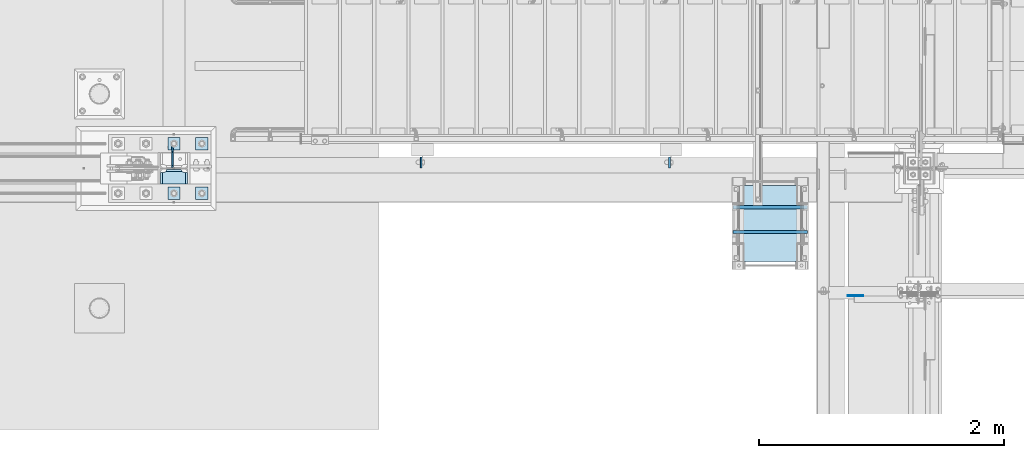
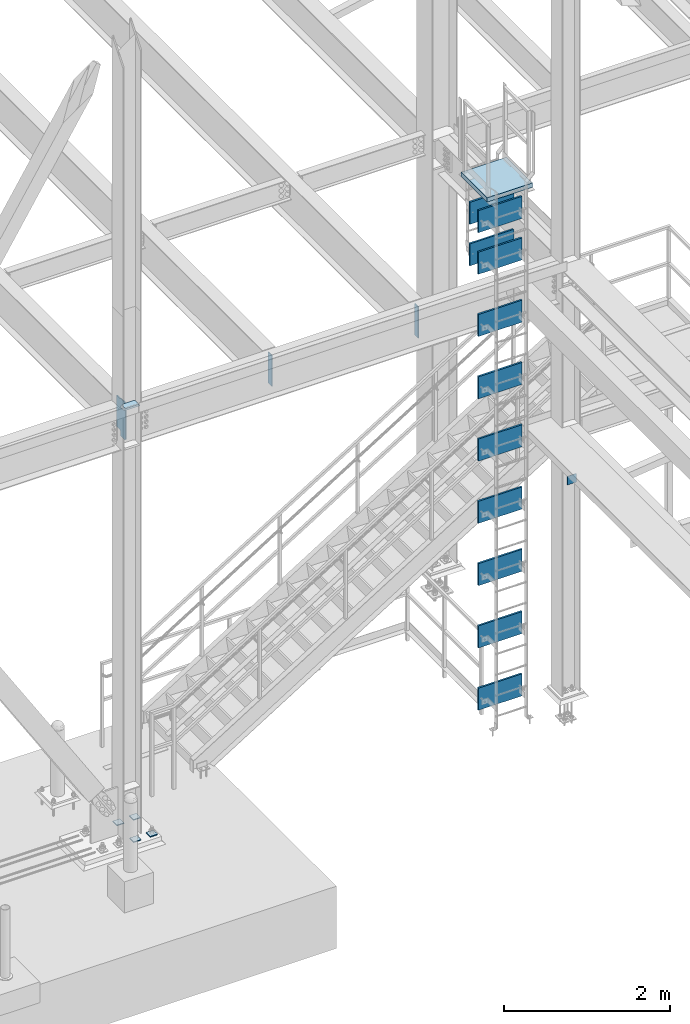
# One storey, part 3404 of 3843: 21 plates, 16 elements without a shape of their own.
"""IFC2X3 building model written with IfcOpenShell, lengths in millimetres."""

from ifc_helpers import new_model, si_unit, frame, origin_with_axes, place, context, subcontext, project, spatial, faceted_brep, material, type_object, element, aggregate, save


model = new_model("IFC2X3")

# Units and contexts
model_context = context("Model", 3, precision=1e-05, world=origin_with_axes())
body_context = subcontext(model_context, "Body", "Model", "MODEL_VIEW")
ifc_project = project(units=[si_unit("LENGTHUNIT", "METRE", prefix="MILLI"), si_unit("AREAUNIT", "SQUARE_METRE"), si_unit("VOLUMEUNIT", "CUBIC_METRE"), si_unit("MASSUNIT", "GRAM", prefix="KILO"), si_unit("TIMEUNIT", "SECOND"), si_unit("PLANEANGLEUNIT", "RADIAN"), si_unit("SOLIDANGLEUNIT", "STERADIAN"), si_unit("THERMODYNAMICTEMPERATUREUNIT", "DEGREE_CELSIUS"), si_unit("LUMINOUSINTENSITYUNIT", "LUMEN")], contexts=[model_context])

# Site, building, storey
site_placement = place(None, origin_with_axes())
site = spatial("IfcSite", under=ifc_project, at=site_placement, CompositionType="ELEMENT")
building_placement = place(site_placement, origin_with_axes())
building = spatial("IfcBuilding", under=site, at=building_placement, Name="Undefined", CompositionType="ELEMENT")
storey_placement = place(building_placement, origin_with_axes())
storey = spatial("IfcBuildingStorey", under=building, at=storey_placement, Name="Undefined", CompositionType="ELEMENT", Elevation=0.0)

# Assembly, plate
assembly_1_placement = place(storey_placement, origin_with_axes())
assembly_1 = element("IfcElementAssembly", 1, at=assembly_1_placement, inside=storey, Name="PLYWOOD", AssemblyPlace="NOTDEFINED", PredefinedType="NOTDEFINED")
ifc_material_1 = material(Name="TIMBER/PLYWOOD")
plate_type_1 = type_object("IfcPlateType", PredefinedType="NOTDEFINED")
plate_1_placement = place(assembly_1_placement, frame((35356.7999999986, 88811.8271118164, 37345.1994628906), z_axis=(0.0, 0.0, -1.0), x_axis=(0.0, -1.0, 0.0)))
plate_1 = element("IfcPlate", 2, at=plate_1_placement, type_object=plate_type_1, material=ifc_material_1, Name="PLYWOOD", context=body_context, shape_type="Brep", body=[
    faceted_brep([(0.0, -304.799999999999, 0.0), (0.0, -304.800000000003, 323.849999999999), (0.0, 304.800000000003, 323.849999999999), (0.0, 304.799999999999, 0.0), (25.3999999999942, -304.800000000003, 323.849999999999), (25.3999999999942, 304.800000000003, 323.849999999999), (25.4000000002561, -304.799999999999, -8.00355337560177e-11), (25.4000000002561, 304.799999999999, -8.00355337560177e-11)], [[[0, 1, 2, 3]], [[1, 4, 5, 2]], [[4, 6, 7, 5]], [[6, 0, 3, 7]], [[5, 7, 3, 2]], [[6, 4, 1, 0]]]),
])
aggregate(assembly_1, [plate_1])

assembly_2_placement = place(storey_placement, origin_with_axes())
assembly_2 = element("IfcElementAssembly", 3, at=assembly_2_placement, inside=storey, Name="PLYWOOD", AssemblyPlace="NOTDEFINED", PredefinedType="NOTDEFINED")
plate_2_placement = place(assembly_2_placement, frame((35356.7999023562, 88608.6271118164, 30944.3968505849), z_axis=(0.0, 0.0, -1.0), x_axis=(0.0, -1.0, 0.0)))
plate_2 = element("IfcPlate", 4, at=plate_2_placement, type_object=plate_type_1, material=ifc_material_1, Name="PLYWOOD", context=body_context, shape_type="Brep", body=[
    faceted_brep([(0.0, -304.799999999999, 0.0), (0.0, -304.800000000003, 323.849999999999), (0.0, 304.800000000003, 323.849999999999), (0.0, 304.799999999999, 0.0), (25.3999999999942, -304.800000000003, 323.849999999999), (25.3999999999942, 304.800000000003, 323.849999999999), (25.4000000002561, -304.799999999999, -8.00355337560177e-11), (25.4000000002561, 304.799999999999, -8.00355337560177e-11)], [[[0, 1, 2, 3]], [[1, 4, 5, 2]], [[4, 6, 7, 5]], [[6, 0, 3, 7]], [[5, 7, 3, 2]], [[6, 4, 1, 0]]]),
])
aggregate(assembly_2, [plate_2])

assembly_3_placement = place(storey_placement, origin_with_axes())
assembly_3 = element("IfcElementAssembly", 5, at=assembly_3_placement, inside=storey, Name="PLYWOOD", AssemblyPlace="NOTDEFINED", PredefinedType="NOTDEFINED")
plate_3_placement = place(assembly_3_placement, frame((35356.7996456707, 88608.6271118164, 31858.7418881835), z_axis=(0.0, 0.0, -1.0), x_axis=(0.0, -1.0, 0.0)))
plate_3 = element("IfcPlate", 6, at=plate_3_placement, type_object=plate_type_1, material=ifc_material_1, Name="PLYWOOD", context=body_context, shape_type="Brep", body=[
    faceted_brep([(0.0, -304.799999999999, 0.0), (0.0, -304.800000000003, 323.849999999999), (0.0, 304.800000000003, 323.849999999999), (0.0, 304.799999999999, 0.0), (25.3999999999942, -304.800000000003, 323.849999999999), (25.3999999999942, 304.800000000003, 323.849999999999), (25.4000000002561, -304.799999999999, -8.00355337560177e-11), (25.4000000002561, 304.799999999999, -8.00355337560177e-11)], [[[0, 1, 2, 3]], [[1, 4, 5, 2]], [[4, 6, 7, 5]], [[6, 0, 3, 7]], [[5, 7, 3, 2]], [[6, 4, 1, 0]]]),
])
aggregate(assembly_3, [plate_3])

assembly_4_placement = place(storey_placement, origin_with_axes())
assembly_4 = element("IfcElementAssembly", 7, at=assembly_4_placement, inside=storey, Name="PLYWOOD", AssemblyPlace="NOTDEFINED", PredefinedType="NOTDEFINED")
plate_4_placement = place(assembly_4_placement, frame((35356.7996456707, 88608.6271118164, 32773.1416442871), z_axis=(0.0, 0.0, -1.0), x_axis=(0.0, -1.0, 0.0)))
plate_4 = element("IfcPlate", 8, at=plate_4_placement, type_object=plate_type_1, material=ifc_material_1, Name="PLYWOOD", context=body_context, shape_type="Brep", body=[
    faceted_brep([(0.0, -304.799999999999, 0.0), (0.0, -304.800000000003, 323.849999999999), (0.0, 304.800000000003, 323.849999999999), (0.0, 304.799999999999, 0.0), (25.3999999999942, -304.800000000003, 323.849999999999), (25.3999999999942, 304.800000000003, 323.849999999999), (25.4000000002561, -304.799999999999, -8.00355337560177e-11), (25.4000000002561, 304.799999999999, -8.00355337560177e-11)], [[[0, 1, 2, 3]], [[1, 4, 5, 2]], [[4, 6, 7, 5]], [[6, 0, 3, 7]], [[5, 7, 3, 2]], [[6, 4, 1, 0]]]),
])
aggregate(assembly_4, [plate_4])

assembly_5_placement = place(storey_placement, origin_with_axes())
assembly_5 = element("IfcElementAssembly", 9, at=assembly_5_placement, inside=storey, Name="PLYWOOD", AssemblyPlace="NOTDEFINED", PredefinedType="NOTDEFINED")
plate_5_placement = place(assembly_5_placement, frame((35356.7996456707, 88608.6271118164, 33687.5416442871), z_axis=(0.0, 0.0, -1.0), x_axis=(0.0, -1.0, 0.0)))
plate_5 = element("IfcPlate", 10, at=plate_5_placement, type_object=plate_type_1, material=ifc_material_1, Name="PLYWOOD", context=body_context, shape_type="Brep", body=[
    faceted_brep([(0.0, -304.799999999999, 0.0), (0.0, -304.800000000003, 323.849999999999), (0.0, 304.800000000003, 323.849999999999), (0.0, 304.799999999999, 0.0), (25.3999999999942, -304.800000000003, 323.849999999999), (25.3999999999942, 304.800000000003, 323.849999999999), (25.4000000002561, -304.799999999999, -8.00355337560177e-11), (25.4000000002561, 304.799999999999, -8.00355337560177e-11)], [[[0, 1, 2, 3]], [[1, 4, 5, 2]], [[4, 6, 7, 5]], [[6, 0, 3, 7]], [[5, 7, 3, 2]], [[6, 4, 1, 0]]]),
])
aggregate(assembly_5, [plate_5])

assembly_6_placement = place(storey_placement, origin_with_axes())
assembly_6 = element("IfcElementAssembly", 11, at=assembly_6_placement, inside=storey, Name="PLYWOOD", AssemblyPlace="NOTDEFINED", PredefinedType="NOTDEFINED")
plate_6_placement = place(assembly_6_placement, frame((35356.7996456707, 88608.6271118164, 34601.9416442871), z_axis=(0.0, 0.0, -1.0), x_axis=(0.0, -1.0, 0.0)))
plate_6 = element("IfcPlate", 12, at=plate_6_placement, type_object=plate_type_1, material=ifc_material_1, Name="PLYWOOD", context=body_context, shape_type="Brep", body=[
    faceted_brep([(0.0, -304.799999999999, 0.0), (0.0, -304.800000000003, 323.849999999999), (0.0, 304.800000000003, 323.849999999999), (0.0, 304.799999999999, 0.0), (25.3999999999942, -304.800000000003, 323.849999999999), (25.3999999999942, 304.800000000003, 323.849999999999), (25.4000000002561, -304.799999999999, -8.00355337560177e-11), (25.4000000002561, 304.799999999999, -8.00355337560177e-11)], [[[0, 1, 2, 3]], [[1, 4, 5, 2]], [[4, 6, 7, 5]], [[6, 0, 3, 7]], [[5, 7, 3, 2]], [[6, 4, 1, 0]]]),
])
aggregate(assembly_6, [plate_6])

assembly_7_placement = place(storey_placement, origin_with_axes())
assembly_7 = element("IfcElementAssembly", 13, at=assembly_7_placement, inside=storey, Name="PLYWOOD", AssemblyPlace="NOTDEFINED", PredefinedType="NOTDEFINED")
plate_7_placement = place(assembly_7_placement, frame((35356.7996456707, 88608.6271118164, 35516.3416442871), z_axis=(0.0, 0.0, -1.0), x_axis=(0.0, -1.0, 0.0)))
plate_7 = element("IfcPlate", 14, at=plate_7_placement, type_object=plate_type_1, material=ifc_material_1, Name="PLYWOOD", context=body_context, shape_type="Brep", body=[
    faceted_brep([(0.0, -304.799999999999, 0.0), (0.0, -304.800000000003, 323.849999999999), (0.0, 304.800000000003, 323.849999999999), (0.0, 304.799999999999, 0.0), (25.3999999999942, -304.800000000003, 323.849999999999), (25.3999999999942, 304.800000000003, 323.849999999999), (25.4000000002561, -304.799999999999, -8.00355337560177e-11), (25.4000000002561, 304.799999999999, -8.00355337560177e-11)], [[[0, 1, 2, 3]], [[1, 4, 5, 2]], [[4, 6, 7, 5]], [[6, 0, 3, 7]], [[5, 7, 3, 2]], [[6, 4, 1, 0]]]),
])
aggregate(assembly_7, [plate_7])

assembly_8_placement = place(storey_placement, origin_with_axes())
assembly_8 = element("IfcElementAssembly", 15, at=assembly_8_placement, inside=storey, Name="PLYWOOD", AssemblyPlace="NOTDEFINED", PredefinedType="NOTDEFINED")
plate_8_placement = place(assembly_8_placement, frame((35356.7996456707, 88608.6271118164, 36430.7416442871), z_axis=(0.0, 0.0, -1.0), x_axis=(0.0, -1.0, 0.0)))
plate_8 = element("IfcPlate", 16, at=plate_8_placement, type_object=plate_type_1, material=ifc_material_1, Name="PLYWOOD", context=body_context, shape_type="Brep", body=[
    faceted_brep([(0.0, -304.799999999999, 0.0), (0.0, -304.800000000003, 323.849999999999), (0.0, 304.800000000003, 323.849999999999), (0.0, 304.799999999999, 0.0), (25.3999999999942, -304.800000000003, 323.849999999999), (25.3999999999942, 304.800000000003, 323.849999999999), (25.4000000002561, -304.799999999999, -8.00355337560177e-11), (25.4000000002561, 304.799999999999, -8.00355337560177e-11)], [[[0, 1, 2, 3]], [[1, 4, 5, 2]], [[4, 6, 7, 5]], [[6, 0, 3, 7]], [[5, 7, 3, 2]], [[6, 4, 1, 0]]]),
])
aggregate(assembly_8, [plate_8])

assembly_9_placement = place(storey_placement, origin_with_axes())
assembly_9 = element("IfcElementAssembly", 17, at=assembly_9_placement, inside=storey, Name="PLYWOOD", AssemblyPlace="NOTDEFINED", PredefinedType="NOTDEFINED")
plate_9_placement = place(assembly_9_placement, frame((35356.7996456707, 88608.6271118164, 37345.1416442871), z_axis=(0.0, 0.0, -1.0), x_axis=(0.0, -1.0, 0.0)))
plate_9 = element("IfcPlate", 18, at=plate_9_placement, type_object=plate_type_1, material=ifc_material_1, Name="PLYWOOD", context=body_context, shape_type="Brep", body=[
    faceted_brep([(0.0, -304.799999999999, 0.0), (0.0, -304.800000000003, 323.849999999999), (0.0, 304.800000000003, 323.849999999999), (0.0, 304.799999999999, 0.0), (25.3999999999942, -304.800000000003, 323.849999999999), (25.3999999999942, 304.800000000003, 323.849999999999), (25.4000000002561, -304.799999999999, -8.00355337560177e-11), (25.4000000002561, 304.799999999999, -8.00355337560177e-11)], [[[0, 1, 2, 3]], [[1, 4, 5, 2]], [[4, 6, 7, 5]], [[6, 0, 3, 7]], [[5, 7, 3, 2]], [[6, 4, 1, 0]]]),
])
aggregate(assembly_9, [plate_9])

assembly_10_placement = place(storey_placement, origin_with_axes())
assembly_10 = element("IfcElementAssembly", 19, at=assembly_10_placement, inside=storey, Name="PLYWOOD", AssemblyPlace="NOTDEFINED", PredefinedType="NOTDEFINED")
plate_10_placement = place(assembly_10_placement, frame((35356.8000000001, 88811.8271118164, 37954.7995300293), z_axis=(0.0, 0.0, -1.0), x_axis=(0.0, -1.0, 0.0)))
plate_10 = element("IfcPlate", 20, at=plate_10_placement, type_object=plate_type_1, material=ifc_material_1, Name="PLYWOOD", context=body_context, shape_type="Brep", body=[
    faceted_brep([(0.0, -304.799999999999, 0.0), (0.0, -304.800000000003, 323.849999999999), (0.0, 304.800000000003, 323.849999999999), (0.0, 304.799999999999, 0.0), (25.3999999999942, -304.800000000003, 323.849999999999), (25.3999999999942, 304.800000000003, 323.849999999999), (25.4000000002561, -304.799999999999, -8.00355337560177e-11), (25.4000000002561, 304.799999999999, -8.00355337560177e-11)], [[[0, 1, 2, 3]], [[1, 4, 5, 2]], [[4, 6, 7, 5]], [[6, 0, 3, 7]], [[5, 7, 3, 2]], [[6, 4, 1, 0]]]),
])
aggregate(assembly_10, [plate_10])

assembly_11_placement = place(storey_placement, origin_with_axes())
assembly_11 = element("IfcElementAssembly", 21, at=assembly_11_placement, inside=storey, Name="PLYWOOD", AssemblyPlace="NOTDEFINED", PredefinedType="NOTDEFINED")
plate_11_placement = place(assembly_11_placement, frame((35356.8000000001, 88608.6271118164, 37954.7995300293), z_axis=(0.0, 0.0, -1.0), x_axis=(0.0, -1.0, 0.0)))
plate_11 = element("IfcPlate", 22, at=plate_11_placement, type_object=plate_type_1, material=ifc_material_1, Name="PLYWOOD", context=body_context, shape_type="Brep", body=[
    faceted_brep([(0.0, -304.799999999999, 0.0), (0.0, -304.800000000003, 323.849999999999), (0.0, 304.800000000003, 323.849999999999), (0.0, 304.799999999999, 0.0), (25.3999999999942, -304.800000000003, 323.849999999999), (25.3999999999942, 304.800000000003, 323.849999999999), (25.4000000002561, -304.799999999999, -8.00355337560177e-11), (25.4000000002561, 304.799999999999, -8.00355337560177e-11)], [[[0, 1, 2, 3]], [[1, 4, 5, 2]], [[4, 6, 7, 5]], [[6, 0, 3, 7]], [[5, 7, 3, 2]], [[6, 4, 1, 0]]]),
])
aggregate(assembly_11, [plate_11])

assembly_12_placement = place(storey_placement, origin_with_axes())
assembly_12 = element("IfcElementAssembly", 23, at=assembly_12_placement, inside=storey, Name="GALV. GRATING", AssemblyPlace="NOTDEFINED", PredefinedType="RIGID_FRAME")
ifc_material_2 = material()
plate_type_2 = type_object("IfcPlateType", PredefinedType="NOTDEFINED")
plate_12_placement = place(assembly_12_placement, frame((35042.4751477703, 88353.7015620001, 38254.7812469482), z_axis=(0.0, 1.0, 0.0), x_axis=(1.0, 0.0, 0.0)))
plate_12 = element("IfcPlate", 24, at=plate_12_placement, type_object=plate_type_2, material=ifc_material_2, Name="GALV. GRATING", context=body_context, shape_type="Brep", body=[
    faceted_brep([(0.0, -31.75, 0.0), (-1.8007995095104e-08, -31.75, 624.28438720922), (-1.8007995095104e-08, 31.75, 624.28438720922), (0.0, 31.75, 0.0), (628.650032072364, -31.75, 624.284387209045), (628.650032072364, 31.75, 624.284387209045), (628.650032092555, -31.75, -4.36557456851006e-11), (628.650032092555, 31.75, -4.36557456851006e-11)], [[[0, 1, 2, 3]], [[1, 4, 5, 2]], [[4, 6, 7, 5]], [[6, 0, 3, 7]], [[5, 7, 3, 2]], [[6, 4, 1, 0]]]),
])
aggregate(assembly_12, [plate_12])

assembly_13_placement = place(storey_placement, origin_with_axes())
assembly_13 = element("IfcElementAssembly", 25, at=assembly_13_placement, inside=storey, Name="BEAM", AssemblyPlace="NOTDEFINED", PredefinedType="RIGID_FRAME")
ifc_material_3 = material(Name="STEEL/A572-50")
plate_type_3 = type_object("IfcPlateType", PredefinedType="NOTDEFINED")
plate_13_placement = place(assembly_13_placement, frame((35991.8000305176, 88074.5000000001, 33909.0000061035), z_axis=(0.0, 0.0, 1.0), x_axis=(1.0, 0.0, 0.0)))
plate_13 = element("IfcPlate", 26, at=plate_13_placement, type_object=plate_type_3, material=ifc_material_3, Name="PLATE", context=body_context, shape_type="Brep", body=[
    faceted_brep([(0.0, -3.17499999999927, 0.0), (-6.10351708019152e-06, -3.17500000000291, 126.999993896483), (-6.10351708019152e-06, 3.17500000000291, 126.999993896483), (0.0, 3.17499999999927, 0.0), (127.0, -3.17500000000291, 127.0), (127.0, 3.17500000000291, 127.0), (127.0, -3.17500000000291, 0.0), (127.0, 3.17500000000291, 0.0)], [[[0, 1, 2, 3]], [[1, 4, 5, 2]], [[4, 6, 7, 5]], [[6, 0, 3, 7]], [[5, 7, 3, 2]], [[6, 4, 1, 0]]]),
])
aggregate(assembly_13, [plate_13])

assembly_14_placement = place(storey_placement, origin_with_axes())
assembly_14 = element("IfcElementAssembly", 27, at=assembly_14_placement, inside=storey, Name="COLUMN", AssemblyPlace="NOTDEFINED", PredefinedType="RIGID_FRAME")
plate_type_4 = type_object("IfcPlateType", PredefinedType="NOTDEFINED")
plate_14_placement = place(assembly_14_placement, frame((30592.7125, 89110.34375, 36423.6), z_axis=(-1.0, 0.0, 0.0), x_axis=(0.0, -1.0, 0.0)))
plate_14 = element("IfcPlate", 28, at=plate_14_placement, type_object=plate_type_4, material=ifc_material_3, Name="PLATE", context=body_context, shape_type="Brep", body=[
    faceted_brep([(15.8628540477987, 9.2764413265686, 176.60415524448), (17.8394465694582, 12.6999999999971, 178.580747766144), (17.8394465694582, 12.6999999999971, 46.8442522338592), (15.8628540477985, 9.2764413265686, 48.8208447555226), (8.33959589993262, -3.75422402399272, 52.6541362449789), (3.17474995228986, -12.6999999999971, 53.4721674797547), (3.17474995228986, -12.6999999999971, 171.952832520248), (8.33959589993288, -3.75422402399272, 172.770863755024), (122.237500000527, 12.6999999999971, 17.8401965694902), (122.23750000009, -12.6999999999971, 3.17549995231457), (26.9874992371479, -12.6999999999971, 3.17549995231457), (26.9874992375844, 12.6999999999971, 17.8401965694902), (26.9874992430996, 12.6999999999971, 207.585803430506), (26.9874992435361, -12.6999999999971, 222.250500047681), (122.237500006479, -12.6999999999971, 222.250500047681), (122.237500006042, 12.6999999999971, 207.585803430506), (8.33959589993174, -12.6999999999971, 172.770863755024), (15.8628540477948, -12.6999999999971, 176.60415524448), (21.833345518462, -12.6999999999971, 182.574646715148), (21.833345518462, 12.6999999999971, 182.574646715148), (25.6666370079183, -12.6999999999971, 190.097904863011), (25.6666370079183, 12.6999999999971, 190.097904863011), (26.9874992370605, -12.6999999999971, 198.437500762942), (26.9874992370605, 12.6999999999971, 198.437500762942), (26.9874992370605, -12.6999999999971, 26.9874992370605), (26.9874992370605, 12.6999999999971, 26.9874992370605), (25.6666370079183, -12.6999999999971, 35.3270951369923), (25.6666370079183, 12.6999999999971, 35.3270951369923), (21.833345518462, -12.6999999999971, 42.8503532848626), (21.833345518462, 12.6999999999971, 42.8503532848626), (15.8628540477948, -12.6999999999971, 48.8208447555226), (8.33959589993174, -12.6999999999971, 52.6541362449789)], [[[0, 1, 2, 3, 4, 5, 6, 7]], [[8, 9, 10, 11]], [[12, 13, 14, 15]], [[16, 7, 6]], [[16, 17, 0, 7]], [[17, 18, 19, 1, 0]], [[18, 20, 21, 19]], [[20, 22, 23, 21]], [[23, 22, 13, 12]], [[9, 8, 15, 14]], [[24, 25, 11, 10]], [[24, 26, 27, 25]], [[26, 28, 29, 27]], [[29, 28, 30, 3, 2]], [[30, 31, 4, 3]], [[31, 5, 4]], [[19, 21, 23, 12, 15, 8, 11, 25, 27, 29, 2, 1]], [[31, 30, 28, 26, 24, 10, 9, 14, 13, 22, 20, 18, 17, 16, 6, 5]]]),
])

# Assembly, plates
assembly_15_placement = place(storey_placement, origin_with_axes())
assembly_15 = element("IfcElementAssembly", 29, at=assembly_15_placement, inside=storey, Name="TEMPLATE", AssemblyPlace="NOTDEFINED", PredefinedType="RIGID_FRAME")
plate_type_5 = type_object("IfcPlateType", PredefinedType="NOTDEFINED")
plate_15_placement = place(assembly_15_placement, frame((30657.8, 88963.5, 30130.75), z_axis=(0.0, -1.0, 0.0), x_axis=(1.0, 0.0, 0.0)))
plate_15 = element("IfcPlate", 30, at=plate_15_placement, type_object=plate_type_5, material=ifc_material_3, Name="Washer Plate", context=body_context, shape_type="Brep", body=[
    faceted_brep([(0.0, -6.3499999046162, 0.0), (-1.67347025126219e-10, -6.35000000000582, 101.600000000151), (-1.67347025126219e-10, 6.35000000000582, 101.600000000151), (7.27595761418343e-12, 6.3499999046162, 0.0), (101.599998474121, -6.34999999999854, 101.599998474121), (101.599998474121, 6.34999999999854, 101.599998474121), (101.6, -6.34999999999854, 0.0), (101.6, 6.34999999999854, 0.0)], [[[0, 1, 2, 3]], [[1, 4, 5, 2]], [[4, 6, 7, 5]], [[6, 0, 3, 7]], [[5, 7, 3, 2]], [[6, 4, 1, 0]]]),
])
plate_16_placement = place(assembly_15_placement, frame((30657.8, 89369.9, 30130.75), z_axis=(0.0, -1.0, 0.0), x_axis=(1.0, 0.0, 0.0)))
plate_16 = element("IfcPlate", 31, at=plate_16_placement, type_object=plate_type_5, material=ifc_material_3, Name="Washer Plate", context=body_context, shape_type="Brep", body=[
    faceted_brep([(0.0, -6.3499999046162, 0.0), (-1.67347025126219e-10, -6.35000000000582, 101.600000000151), (-1.67347025126219e-10, 6.35000000000582, 101.600000000151), (7.27595761418343e-12, 6.3499999046162, 0.0), (101.599998474121, -6.34999999999854, 101.599998474121), (101.599998474121, 6.34999999999854, 101.599998474121), (101.6, -6.34999999999854, 0.0), (101.6, 6.34999999999854, 0.0)], [[[0, 1, 2, 3]], [[1, 4, 5, 2]], [[4, 6, 7, 5]], [[6, 0, 3, 7]], [[5, 7, 3, 2]], [[6, 4, 1, 0]]]),
])
plate_17_placement = place(assembly_15_placement, frame((30429.2, 88963.5, 30130.75), z_axis=(0.0, -1.0, 0.0), x_axis=(1.0, 0.0, 0.0)))
plate_17 = element("IfcPlate", 32, at=plate_17_placement, type_object=plate_type_5, material=ifc_material_3, Name="Washer Plate", context=body_context, shape_type="Brep", body=[
    faceted_brep([(0.0, -6.3499999046162, 0.0), (-1.67347025126219e-10, -6.35000000000582, 101.600000000151), (-1.67347025126219e-10, 6.35000000000582, 101.600000000151), (7.27595761418343e-12, 6.3499999046162, 0.0), (101.599998474121, -6.34999999999854, 101.599998474121), (101.599998474121, 6.34999999999854, 101.599998474121), (101.6, -6.34999999999854, 0.0), (101.6, 6.34999999999854, 0.0)], [[[0, 1, 2, 3]], [[1, 4, 5, 2]], [[4, 6, 7, 5]], [[6, 0, 3, 7]], [[5, 7, 3, 2]], [[6, 4, 1, 0]]]),
])
plate_18_placement = place(assembly_15_placement, frame((30429.2, 89369.9, 30130.75), z_axis=(0.0, -1.0, 0.0), x_axis=(1.0, 0.0, 0.0)))
plate_18 = element("IfcPlate", 33, at=plate_18_placement, type_object=plate_type_5, material=ifc_material_3, Name="Washer Plate", context=body_context, shape_type="Brep", body=[
    faceted_brep([(0.0, -6.3499999046162, 0.0), (-1.67347025126219e-10, -6.35000000000582, 101.600000000151), (-1.67347025126219e-10, 6.35000000000582, 101.600000000151), (7.27595761418343e-12, 6.3499999046162, 0.0), (101.599998474121, -6.34999999999854, 101.599998474121), (101.599998474121, 6.34999999999854, 101.599998474121), (101.6, -6.34999999999854, 0.0), (101.6, 6.34999999999854, 0.0)], [[[0, 1, 2, 3]], [[1, 4, 5, 2]], [[4, 6, 7, 5]], [[6, 0, 3, 7]], [[5, 7, 3, 2]], [[6, 4, 1, 0]]]),
])
aggregate(assembly_15, [plate_15, plate_16, plate_17, plate_18])

# Plate
plate_type_6 = type_object("IfcPlateType", PredefinedType="NOTDEFINED")
plate_19_placement = place(assembly_14_placement, frame((30468.8874999046, 89121.45625, 35877.5), z_axis=(0.0, 0.707106781186548, 0.707106781186548), x_axis=(5.70000238222118e-08, 0.707106781186546, -0.707106781186546)))
plate_19 = element("IfcPlate", 34, at=plate_19_placement, type_object=plate_type_6, material=ifc_material_3, Name="PLATE", context=body_context, shape_type="Brep", body=[
    faceted_brep([(0.0, -6.3499999046162, 0.0), (-363.700372901621, -6.34999999999854, 363.700372901469), (-363.700372901621, 6.34999999999854, 363.700372901469), (7.27595761418343e-12, 6.3499999046162, 0.0), (-363.700372901338, -6.34999999999854, 390.641141264845), (-363.700372901338, 6.34999999999854, 390.641141264845), (-290.174525774113, -6.34999999999854, 464.166988122408), (-290.174525774113, 6.34999999999854, 464.166988122408), (-286.054349305959, -6.34999999999854, 461.413974221941), (-286.054349305959, 6.34999999999854, 461.413974221941), (-281.194269787906, -6.34999999999854, 460.447244299372), (-281.194269787906, 6.34999999999854, 460.447244299372), (-276.334190269838, -6.34999999999854, 461.413974222), (-276.334190269838, 6.34999999999854, 461.413974222), (-272.214013801662, -6.34999999999854, 464.16698812251), (-272.214013801662, 6.34999999999854, 464.16698812251), (-218.332476939475, -6.34999999999854, 518.048524984726), (-218.332476939475, 6.34999999999854, 518.048524984726), (104.956743417526, -6.34999999999854, 194.759304627849), (104.956743417526, 6.34999999999854, 194.759304627849), (51.0752065553315, -6.34999999999854, 140.877767765633), (51.0752065553315, 6.34999999999854, 140.877767765633), (48.3221926548213, -6.34999999999854, 136.757591297457), (48.3221926548213, 6.34999999999854, 136.757591297457), (47.3554627322083, -6.34999999999854, 131.897511779389), (47.3554627322083, 6.34999999999854, 131.897511779389), (48.3221926547776, -6.34999999999854, 127.037432261335), (48.3221926547776, 6.34999999999854, 127.037432261335), (51.0752065552297, -6.34999999999854, 122.917255793189), (51.0752065552297, 6.34999999999854, 122.917255793189), (100.466615355741, -6.34999999999854, 73.5258469927066), (100.466615355741, 6.34999999999854, 73.5258469927066), (26.9407683632217, -6.34999999999854, 1.30967237055302e-10), (26.9407683632217, 6.34999999999854, 1.30967237055302e-10)], [[[0, 1, 2, 3]], [[1, 4, 5, 2]], [[4, 6, 7, 5]], [[6, 8, 9, 7]], [[8, 10, 11, 9]], [[10, 12, 13, 11]], [[12, 14, 15, 13]], [[14, 16, 17, 15]], [[16, 18, 19, 17]], [[18, 20, 21, 19]], [[20, 22, 23, 21]], [[22, 24, 25, 23]], [[24, 26, 27, 25]], [[26, 28, 29, 27]], [[28, 30, 31, 29]], [[30, 32, 33, 31]], [[32, 0, 3, 33]], [[5, 7, 9, 11, 13, 15, 17, 19, 21, 23, 25, 27, 29, 31, 33, 3, 2]], [[32, 30, 28, 26, 24, 22, 20, 18, 16, 14, 12, 10, 8, 6, 4, 1, 0]]]),
])

aggregate(assembly_14, [plate_14, plate_19])

# Assembly, plates
assembly_16_placement = place(storey_placement, origin_with_axes())
assembly_16 = element("IfcElementAssembly", 35, at=assembly_16_placement, inside=storey, Name="BEAM", AssemblyPlace="NOTDEFINED", PredefinedType="RIGID_FRAME")
plate_type_7 = type_object("IfcPlateType", PredefinedType="NOTDEFINED")
plate_20_placement = place(assembly_16_placement, frame((34532.8875, 89120.6625, 36398.2), z_axis=(0.0, 1.0, 0.0), x_axis=(0.0, 0.0, -1.0)))
plate_20 = element("IfcPlate", 36, at=plate_20_placement, type_object=plate_type_7, material=ifc_material_3, Name="PLATE", context=body_context, shape_type="Brep", body=[
    faceted_brep([(0.0, -6.3499999046162, 0.0), (0.0, -6.34999999999854, 88.9000015258789), (0.0, 6.34999999999854, 88.9000015258789), (7.27595761418343e-12, 6.3499999046162, 0.0), (457.199999999997, -6.34999999999854, 88.8999999999942), (457.199999999997, 6.34999999999854, 88.8999999999942), (457.199999999997, -6.34999999999854, 0.0), (457.199999999997, 6.34999999999854, 0.0)], [[[0, 1, 2, 3]], [[1, 4, 5, 2]], [[4, 6, 7, 5]], [[6, 0, 3, 7]], [[5, 7, 3, 2]], [[6, 4, 1, 0]]]),
])
plate_21_placement = place(assembly_16_placement, frame((32500.8875, 89120.6625, 36398.2), z_axis=(0.0, 1.0, 0.0), x_axis=(0.0, 0.0, -1.0)))
plate_21 = element("IfcPlate", 37, at=plate_21_placement, type_object=plate_type_7, material=ifc_material_3, Name="PLATE", context=body_context, shape_type="Brep", body=[
    faceted_brep([(0.0, -6.3499999046162, 0.0), (0.0, -6.34999999999854, 88.9000015258789), (0.0, 6.34999999999854, 88.9000015258789), (7.27595761418343e-12, 6.3499999046162, 0.0), (457.199999999997, -6.34999999999854, 88.8999999999942), (457.199999999997, 6.34999999999854, 88.8999999999942), (457.199999999997, -6.34999999999854, 0.0), (457.199999999997, 6.34999999999854, 0.0)], [[[0, 1, 2, 3]], [[1, 4, 5, 2]], [[4, 6, 7, 5]], [[6, 0, 3, 7]], [[5, 7, 3, 2]], [[6, 4, 1, 0]]]),
])
aggregate(assembly_16, [plate_20, plate_21])

save(model, "model.ifc")
